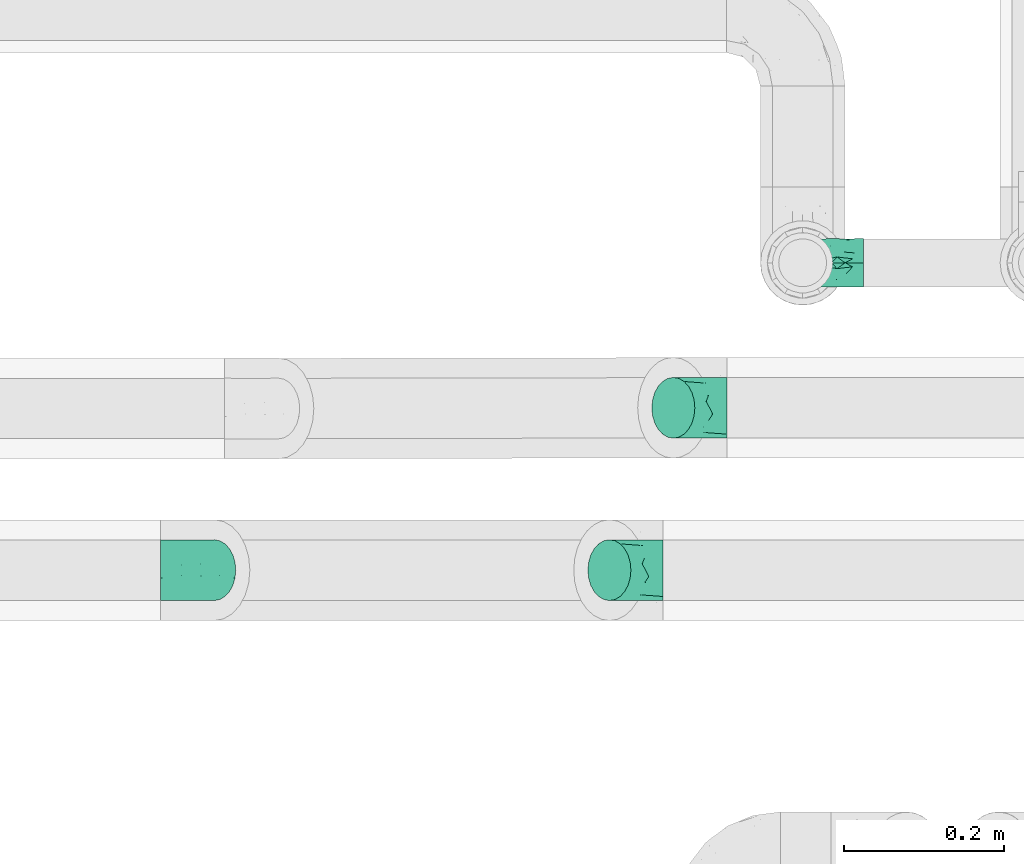
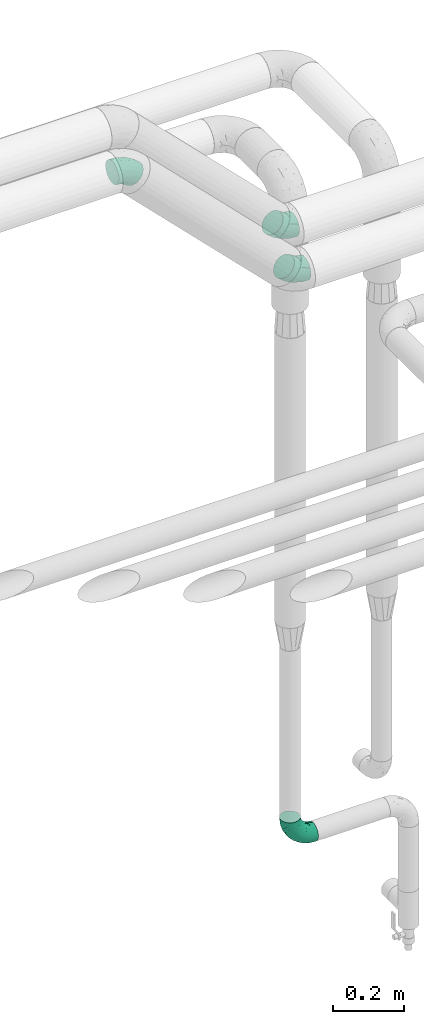
# One storey, part 681 of 827: 4 flow fittings.
"""IFC2X3 building model written with IfcOpenShell, lengths in millimetres."""

from ifc_helpers import new_model, entity, si_unit, converted_unit, derived_unit, direction, frame, origin, place, context, subcontext, project, spatial, faceted_brep, source, transform, mapped, material, type_object, type_shapes, element, save


model = new_model("IFC2X3")

# Units and contexts
model_context = context("Model", 3, precision=0.01, world=origin(), true_north=direction((6.12303176911189e-17, 1.0)))
body_context = subcontext(model_context, "Body", "Model", "MODEL_VIEW")
ifc_project = project(units=[si_unit("LENGTHUNIT", "METRE", prefix="MILLI"), si_unit("AREAUNIT", "SQUARE_METRE"), si_unit("VOLUMEUNIT", "CUBIC_METRE"), converted_unit("PLANEANGLEUNIT", "DEGREE", entity("IfcRatioMeasure", 0.0174532925199433), si_unit("PLANEANGLEUNIT", "RADIAN"), dimensions=[0, 0, 0, 0, 0, 0, 0]), si_unit("MASSUNIT", "GRAM", prefix="KILO"), derived_unit("MASSDENSITYUNIT", [(si_unit("MASSUNIT", "GRAM", prefix="KILO"), 1), (si_unit("LENGTHUNIT", "METRE"), -3)]), derived_unit("MOMENTOFINERTIAUNIT", [(si_unit("LENGTHUNIT", "METRE"), 4)]), si_unit("TIMEUNIT", "SECOND"), si_unit("FREQUENCYUNIT", "HERTZ"), si_unit("THERMODYNAMICTEMPERATUREUNIT", "DEGREE_CELSIUS"), derived_unit("THERMALTRANSMITTANCEUNIT", [(si_unit("MASSUNIT", "GRAM", prefix="KILO"), 1), (si_unit("THERMODYNAMICTEMPERATUREUNIT", "KELVIN"), -1), (si_unit("TIMEUNIT", "SECOND"), -3)]), derived_unit("VOLUMETRICFLOWRATEUNIT", [(si_unit("LENGTHUNIT", "METRE"), 3), (si_unit("TIMEUNIT", "SECOND"), -1)]), derived_unit("MASSFLOWRATEUNIT", [(si_unit("MASSUNIT", "GRAM", prefix="KILO"), 1), (si_unit("TIMEUNIT", "SECOND"), -1)]), derived_unit("ROTATIONALFREQUENCYUNIT", [(si_unit("TIMEUNIT", "SECOND"), -1)]), si_unit("ELECTRICCURRENTUNIT", "AMPERE"), si_unit("ELECTRICVOLTAGEUNIT", "VOLT"), si_unit("POWERUNIT", "WATT"), si_unit("FORCEUNIT", "NEWTON", prefix="KILO"), si_unit("ILLUMINANCEUNIT", "LUX"), si_unit("LUMINOUSFLUXUNIT", "LUMEN"), si_unit("LUMINOUSINTENSITYUNIT", "CANDELA"), derived_unit("USERDEFINED", [(si_unit("MASSUNIT", "GRAM", prefix="KILO"), -1), (si_unit("LENGTHUNIT", "METRE"), -2), (si_unit("TIMEUNIT", "SECOND"), 3), (si_unit("LUMINOUSFLUXUNIT", "LUMEN"), 1)]), derived_unit("LINEARVELOCITYUNIT", [(si_unit("LENGTHUNIT", "METRE"), 1), (si_unit("TIMEUNIT", "SECOND"), -1)]), si_unit("PRESSUREUNIT", "PASCAL"), derived_unit("USERDEFINED", [(si_unit("LENGTHUNIT", "METRE"), -2), (si_unit("MASSUNIT", "GRAM", prefix="KILO"), 1), (si_unit("TIMEUNIT", "SECOND"), -2)]), derived_unit("LINEARFORCEUNIT", [(si_unit("MASSUNIT", "GRAM", prefix="KILO"), 1), (si_unit("LENGTHUNIT", "METRE"), 1), (si_unit("TIMEUNIT", "SECOND"), -2), (si_unit("LENGTHUNIT", "METRE"), -1)]), derived_unit("PLANARFORCEUNIT", [(si_unit("MASSUNIT", "GRAM", prefix="KILO"), 1), (si_unit("LENGTHUNIT", "METRE"), 1), (si_unit("TIMEUNIT", "SECOND"), -2), (si_unit("LENGTHUNIT", "METRE"), -2)])], contexts=[model_context])

# Site, building, storey
site_placement = place(None, origin())
site = spatial("IfcSite", under=ifc_project, at=site_placement, CompositionType="ELEMENT")
building_placement = place(site_placement, origin())
building = spatial("IfcBuilding", under=site, at=building_placement, CompositionType="ELEMENT")
storey_placement = place(building_placement, frame((0.0, 0.0, 28200.0)))
storey = spatial("IfcBuildingStorey", under=building, at=storey_placement, Name="08", CompositionType="ELEMENT", Elevation=28200.0)

# Flow fittings
ifc_material = material()
pipe_fitting_type_1 = type_object("IfcPipeFittingType", Name="ADSK_1", PredefinedType="NOTDEFINED", material=ifc_material)
shared_shape_1 = source(origin(), body_context, "Body", "Brep", [
    faceted_brep([(-76.0, 15.07, -26.11), (-76.0, 7.8, -29.12), (-76.0, 0.0, -30.15), (-76.0, -7.8, -29.12), (-76.0, -15.08, -26.11), (-76.0, -21.32, -21.32), (-76.0, -26.11, -15.08), (-76.0, -29.12, -7.8), (-76.0, -30.15, 0.0), (-76.0, -29.12, 7.8), (-76.0, -26.11, 15.07), (-76.0, -21.32, 21.32), (-76.0, -15.08, 26.11), (-76.0, -7.8, 29.12), (-76.0, 0.0, 30.15), (-76.0, 7.8, 29.12), (-76.0, 15.07, 26.11), (-76.0, 21.32, 21.32), (-76.0, 26.11, 15.07), (-76.0, 29.12, 7.8), (-76.0, 30.15, 0.0), (-76.0, 29.12, -7.8), (-76.0, 26.11, -15.08), (-76.0, 21.32, -21.32), (0.0, 76.0, -30.15), (-7.8, 76.0, -29.12), (-15.07, 76.0, -26.11), (-21.32, 76.0, -21.32), (-26.11, 76.0, -15.08), (-29.12, 76.0, -7.8), (-30.15, 76.0, 0.0), (-29.12, 76.0, 7.8), (-26.11, 76.0, 15.07), (-21.32, 76.0, 21.32), (-15.07, 76.0, 26.11), (-7.8, 76.0, 29.12), (0.0, 76.0, 30.15), (7.8, 76.0, 29.12), (15.08, 76.0, 26.11), (21.32, 76.0, 21.32), (26.11, 76.0, 15.07), (29.12, 76.0, 7.8), (30.15, 76.0, 0.0), (29.12, 76.0, -7.8), (26.11, 76.0, -15.08), (21.32, 76.0, -21.32), (15.08, 76.0, -26.11), (7.8, 76.0, -29.12), (10.79, 31.43, 21.07), (4.32, 31.7, 25.72), (1.65, 15.19, 19.92), (-61.17, -27.8, 0.0), (-51.1, -25.49, 9.84), (-56.14, -10.61, 27.27), (-31.7, -4.32, 25.72), (-39.75, 1.72, 29.41), (-43.2, -24.95, 0.0), (-1.86, 1.86, 0.0), (4.49, 7.65, 5.78), (-7.82, -4.61, 5.83), (-56.21, -22.79, 17.21), (-58.98, -3.38, 29.7), (-53.96, 5.6, 30.07), (-10.86, 10.86, 25.48), (-17.2, -2.6, 20.44), (-49.15, -16.01, 22.7), (-22.18, -14.24, 7.99), (-28.4, -17.42, 0.0), (-13.61, -9.88, 0.0), (-39.0, 23.48, 27.76), (-58.76, 12.54, 28.36), (-41.61, 15.41, 29.48), (16.01, 49.15, 22.7), (-58.55, 25.93, 19.53), (-51.53, 33.5, 13.51), (-64.92, 28.76, 12.4), (-7.48, 23.14, 28.25), (-1.72, 39.75, 29.41), (-12.04, 27.88, 29.88), (-63.91, 18.81, 24.52), (-11.63, 65.16, 28.18), (-4.97, 57.02, 30.05), (9.88, 13.61, 0.0), (-62.5, 31.74, 5.02), (-45.17, 30.98, 21.2), (-21.78, 9.76, 28.58), (10.61, 56.14, 27.27), (-32.09, 54.42, 13.26), (22.79, 56.21, 17.21), (15.38, 31.17, 15.63), (25.49, 51.1, 9.84), (21.84, 36.35, 5.92), (24.95, 43.2, 0.0), (3.38, 58.98, 29.7), (-31.17, -15.38, 15.63), (-39.39, 41.78, 15.45), (-34.56, 41.13, 20.79), (-39.81, -23.25, 5.49), (27.8, 61.17, 0.0), (-31.74, 62.5, 5.02), (-53.07, 36.29, 0.0), (-42.95, 42.95, 7.29), (-36.29, 53.07, 0.0), (-19.83, 58.51, 24.79), (-25.48, 60.2, 19.41), (-14.53, 50.96, 28.57), (-13.31, 37.09, 30.07), (-26.16, 40.06, 26.4), (-32.43, -10.35, 21.9), (17.42, 28.4, 0.0), (14.24, 22.18, 7.99), (-38.67, 9.72, 30.15), (-24.66, 17.36, 30.09), (-37.08, 31.49, 24.99), (-49.27, 22.83, 25.24), (-20.8, 38.81, 28.63), (-27.58, 27.58, 29.2), (-36.07, -20.23, 10.71), (-15.19, -6.16, 14.9), (6.6, 15.4, 14.49), (-2.51, 2.51, 11.35), (-65.16, 11.63, -28.18), (-49.15, -16.01, -22.7), (-57.02, 4.97, -30.05), (-25.93, 58.55, -19.53), (-33.5, 51.53, -13.51), (-28.76, 64.92, -12.4), (-60.2, 25.48, -19.41), (-58.51, 19.83, -24.79), (4.61, 7.82, -5.83), (-7.65, -4.49, -5.78), (-2.51, 2.51, -11.35), (-62.5, 31.74, -5.02), (-50.96, 14.53, -28.57), (-37.09, 13.31, -30.07), (-42.95, 42.95, -7.29), (25.49, 51.1, -9.84), (22.79, 56.21, -17.21), (-40.06, 26.16, -26.4), (3.38, 58.98, -29.7), (-5.6, 53.96, -30.07), (-27.88, 12.04, -29.88), (-9.76, 21.78, -28.58), (-23.14, 7.48, -28.25), (-51.1, -25.49, -9.84), (15.38, 31.17, -15.63), (16.01, 49.15, -22.7), (-23.48, 39.0, -27.76), (-12.54, 58.76, -28.36), (-15.41, 41.61, -29.48), (-56.21, -22.79, -17.21), (-9.72, 38.67, -30.15), (-17.36, 24.66, -30.09), (-22.18, -14.24, -7.99), (-41.13, 34.56, -20.79), (-31.74, 62.5, -5.02), (-58.98, -3.38, -29.7), (-31.17, -15.38, -15.63), (-56.14, -10.61, -27.27), (14.24, 22.18, -7.99), (23.25, 39.81, -5.49), (-31.49, 37.08, -24.99), (-15.19, -6.16, -14.9), (1.65, 15.19, -19.92), (-18.81, 63.91, -24.52), (-32.59, -11.62, -20.84), (-31.7, -4.32, -25.72), (-17.2, -2.6, -20.44), (-39.75, 1.72, -29.41), (-54.42, 32.09, -13.26), (-30.98, 45.17, -21.2), (10.61, 56.14, -27.27), (10.23, 31.31, -21.52), (4.32, 31.7, -25.72), (-41.78, 39.39, -15.45), (-1.72, 39.75, -29.41), (-36.35, -21.84, -5.92), (-22.83, 49.27, -25.24), (-38.81, 20.8, -28.63), (-27.58, 27.58, -29.2), (-10.86, 10.86, -25.48), (20.23, 36.07, -10.71), (6.6, 15.4, -14.49)], [[[0, 1, 2, 3, 4, 5, 6, 7, 8, 9, 10, 11, 12, 13, 14, 15, 16, 17, 18, 19, 20, 21, 22, 23]], [[24, 25, 26, 27, 28, 29, 30, 31, 32, 33, 34, 35, 36, 37, 38, 39, 40, 41, 42, 43, 44, 45, 46, 47]], [[48, 49, 50]], [[51, 52, 9]], [[53, 54, 55]], [[9, 52, 10]], [[56, 52, 51]], [[57, 58, 59]], [[11, 10, 60]], [[14, 61, 62]], [[63, 54, 64]], [[65, 12, 11]], [[65, 53, 12]], [[66, 67, 68]], [[69, 70, 71]], [[72, 39, 38]], [[73, 74, 75]], [[15, 70, 16]], [[76, 77, 78]], [[16, 79, 17]], [[13, 61, 14]], [[35, 80, 81]], [[14, 62, 15]], [[17, 73, 18]], [[57, 82, 58]], [[20, 19, 83]], [[75, 19, 18]], [[70, 15, 62]], [[73, 84, 74]], [[78, 85, 76]], [[38, 86, 72]], [[32, 31, 87]], [[88, 89, 90]], [[91, 92, 90]], [[72, 86, 49]], [[36, 93, 37]], [[75, 83, 19]], [[36, 35, 81]], [[60, 94, 65]], [[40, 90, 41]], [[95, 96, 87]], [[88, 90, 40]], [[66, 97, 67]], [[90, 98, 41]], [[40, 39, 88]], [[99, 31, 30]], [[20, 83, 100]], [[101, 102, 100]], [[52, 60, 10]], [[102, 99, 30]], [[96, 103, 104]], [[83, 101, 100]], [[12, 53, 13]], [[104, 103, 33]], [[105, 106, 81]], [[107, 105, 103]], [[64, 54, 108]], [[80, 103, 105]], [[80, 35, 34]], [[34, 33, 103]], [[86, 38, 37]], [[109, 110, 82]], [[71, 111, 112]], [[69, 107, 113]], [[79, 73, 17]], [[114, 113, 84]], [[33, 32, 104]], [[115, 107, 116]], [[105, 115, 106]], [[93, 81, 77]], [[54, 53, 65]], [[61, 53, 55]], [[108, 94, 64]], [[54, 63, 85]], [[93, 86, 37]], [[77, 76, 49]], [[77, 49, 86]], [[49, 63, 50]], [[60, 52, 117]], [[65, 11, 60]], [[39, 72, 88]], [[89, 88, 72]], [[71, 70, 62]], [[79, 70, 114]], [[103, 96, 107]], [[69, 113, 114]], [[112, 106, 116]], [[77, 81, 106]], [[112, 116, 71]], [[112, 55, 85]], [[64, 50, 63]], [[57, 59, 68]], [[32, 87, 104]], [[96, 104, 87]], [[94, 118, 64]], [[50, 119, 89]], [[50, 64, 118]], [[50, 89, 48]], [[81, 93, 36]], [[86, 93, 77]], [[53, 61, 13]], [[62, 61, 55]], [[71, 62, 111]], [[69, 71, 116]], [[95, 101, 74]], [[99, 101, 87]], [[118, 66, 59]], [[117, 97, 66]], [[117, 66, 94]], [[91, 89, 110]], [[91, 110, 109]], [[110, 89, 119]], [[9, 8, 51]], [[98, 90, 92]], [[98, 42, 41]], [[101, 83, 74]], [[101, 99, 102]], [[87, 31, 99]], [[62, 55, 111]], [[55, 112, 111]], [[107, 69, 116]], [[70, 69, 114]], [[107, 96, 113]], [[84, 113, 96]], [[84, 96, 95]], [[114, 84, 73]], [[70, 79, 16]], [[73, 79, 114]], [[54, 85, 55]], [[76, 85, 63]], [[49, 76, 63]], [[77, 106, 78]], [[106, 112, 78]], [[85, 78, 112]], [[73, 75, 18]], [[83, 75, 74]], [[103, 80, 34]], [[81, 80, 105]], [[101, 95, 87]], [[84, 95, 74]], [[106, 115, 116]], [[105, 107, 115]], [[120, 59, 58]], [[82, 110, 58]], [[119, 58, 110]], [[118, 59, 120]], [[66, 68, 59]], [[54, 65, 108]], [[94, 108, 65]], [[66, 118, 94]], [[50, 118, 120]], [[50, 120, 119]], [[119, 120, 58]], [[89, 72, 48]], [[49, 48, 72]], [[60, 117, 94]], [[117, 52, 97]], [[52, 56, 97]], [[67, 97, 56]], [[92, 91, 109]], [[89, 91, 90]], [[121, 1, 0]], [[122, 5, 4]], [[2, 1, 123]], [[124, 125, 126]], [[127, 128, 23]], [[129, 130, 131]], [[100, 132, 20]], [[133, 134, 123]], [[135, 100, 102]], [[136, 137, 44]], [[133, 128, 138]], [[24, 139, 140]], [[141, 142, 143]], [[121, 128, 133]], [[6, 144, 7]], [[137, 145, 146]], [[144, 51, 7]], [[147, 148, 149]], [[144, 6, 150]], [[149, 151, 152]], [[153, 68, 67]], [[154, 128, 127]], [[30, 155, 102]], [[43, 42, 98]], [[156, 3, 2]], [[157, 144, 150]], [[158, 4, 3]], [[24, 140, 25]], [[155, 135, 102]], [[159, 160, 109]], [[30, 29, 155]], [[147, 138, 161]], [[27, 124, 28]], [[57, 129, 82]], [[162, 163, 131]], [[27, 26, 164]], [[148, 26, 25]], [[165, 166, 167]], [[24, 47, 139]], [[143, 168, 141]], [[22, 21, 169]], [[125, 124, 170]], [[148, 25, 140]], [[46, 146, 171]], [[158, 122, 4]], [[0, 23, 128]], [[1, 121, 123]], [[109, 82, 159]], [[45, 44, 137]], [[146, 46, 45]], [[136, 43, 98]], [[132, 21, 20]], [[136, 98, 92]], [[172, 173, 146]], [[46, 171, 47]], [[43, 136, 44]], [[174, 154, 169]], [[171, 173, 175]], [[6, 5, 150]], [[126, 29, 28]], [[176, 56, 144]], [[122, 158, 166]], [[164, 124, 27]], [[177, 161, 170]], [[23, 22, 127]], [[178, 138, 179]], [[133, 178, 134]], [[156, 123, 168]], [[156, 158, 3]], [[168, 143, 166]], [[168, 166, 158]], [[166, 180, 167]], [[173, 171, 146]], [[139, 171, 175]], [[172, 145, 163]], [[173, 180, 142]], [[5, 122, 150]], [[157, 150, 122]], [[137, 136, 181]], [[146, 45, 137]], [[149, 148, 140]], [[164, 148, 177]], [[128, 154, 138]], [[147, 161, 177]], [[152, 134, 179]], [[168, 123, 134]], [[152, 179, 149]], [[152, 175, 142]], [[57, 130, 129]], [[157, 165, 167]], [[22, 169, 127]], [[154, 127, 169]], [[163, 167, 180]], [[162, 157, 167]], [[173, 163, 180]], [[182, 163, 145]], [[123, 156, 2]], [[158, 156, 168]], [[171, 139, 47]], [[140, 139, 175]], [[149, 140, 151]], [[147, 149, 179]], [[174, 135, 125]], [[132, 135, 169]], [[176, 157, 153]], [[176, 153, 67]], [[153, 157, 162]], [[182, 159, 129]], [[181, 160, 159]], [[181, 159, 145]], [[51, 144, 56]], [[51, 8, 7]], [[135, 132, 100]], [[169, 21, 132]], [[126, 155, 29]], [[135, 155, 125]], [[140, 175, 151]], [[175, 152, 151]], [[138, 147, 179]], [[148, 147, 177]], [[138, 154, 161]], [[170, 161, 154]], [[170, 154, 174]], [[177, 170, 124]], [[148, 164, 26]], [[124, 164, 177]], [[173, 142, 175]], [[143, 142, 180]], [[166, 143, 180]], [[168, 134, 141]], [[134, 152, 141]], [[142, 141, 152]], [[124, 126, 28]], [[155, 126, 125]], [[128, 121, 0]], [[123, 121, 133]], [[135, 174, 169]], [[170, 174, 125]], [[134, 178, 179]], [[133, 138, 178]], [[130, 153, 162]], [[68, 153, 130]], [[57, 68, 130]], [[182, 129, 131]], [[159, 82, 129]], [[157, 122, 165]], [[166, 165, 122]], [[163, 162, 167]], [[162, 131, 130]], [[145, 172, 146]], [[163, 173, 172]], [[159, 182, 145]], [[131, 163, 182]], [[56, 176, 67]], [[157, 176, 144]], [[137, 181, 145]], [[181, 136, 160]], [[136, 92, 160]], [[109, 160, 92]]]),
])
type_shapes(pipe_fitting_type_1, [shared_shape_1])
flow_fitting_placement = place(storey_placement, frame((46507.82, 18991.22, 730.0), z_axis=(0.0, -1.0, 0.0), x_axis=(0.0, 0.0, -1.0)))
element("IfcFlowFitting", 1, at=flow_fitting_placement, inside=storey, type_object=pipe_fitting_type_1, material=ifc_material, Name="ADSK_1", ObjectType="ADSK_1", context=body_context, shape_type="MappedRepresentation", body=[
    mapped(shared_shape_1, transform((0.0, 0.0, 0.0), scale=1.0)),
])
pipe_fitting_type_2 = type_object("IfcPipeFittingType", Name="ADSK_1", PredefinedType="NOTDEFINED", material=ifc_material)
shared_shape_2 = source(origin(), body_context, "Body", "Brep", [
    faceted_brep([(-39.35, 19.02, -32.95), (-39.35, 9.85, -36.75), (-39.35, 0.0, -38.05), (-39.35, -9.85, -36.75), (-39.35, -19.03, -32.95), (-39.35, -26.91, -26.91), (-39.35, -32.95, -19.03), (-39.35, -36.75, -9.85), (-39.35, -38.05, 0.0), (-39.35, -36.75, 9.85), (-39.35, -32.95, 19.02), (-39.35, -26.91, 26.91), (-39.35, -19.03, 32.95), (-39.35, -9.85, 36.75), (-39.35, 0.0, 38.05), (-39.35, 9.85, 36.75), (-39.35, 19.02, 32.95), (-39.35, 26.91, 26.91), (-39.35, 32.95, 19.02), (-39.35, 36.75, 9.85), (-39.35, 38.05, 0.0), (-39.35, 36.75, -9.85), (-39.35, 32.95, -19.03), (-39.35, 26.91, -26.91), (27.82, 27.82, -38.05), (20.86, 34.79, -36.75), (14.37, 41.28, -32.95), (8.8, 46.85, -26.91), (4.52, 51.13, -19.03), (1.84, 53.81, -9.85), (0.92, 54.73, 0.0), (1.84, 53.81, 9.85), (4.52, 51.13, 19.02), (8.8, 46.85, 26.91), (14.37, 41.28, 32.95), (20.86, 34.79, 36.75), (27.82, 27.82, 38.05), (34.79, 20.86, 36.75), (41.28, 14.37, 32.95), (46.85, 8.8, 26.91), (51.13, 4.52, 19.02), (53.81, 1.84, 9.85), (54.73, 0.92, 0.0), (53.81, 1.84, -9.85), (51.13, 4.52, -19.03), (46.85, 8.8, -26.91), (41.28, 14.37, -32.95), (34.79, 20.86, -36.75), (-16.48, -28.6, 22.48), (-9.83, -32.19, 13.52), (8.97, -21.66, 21.67), (-20.54, -35.57, 0.0), (-4.91, -33.52, 0.0), (-13.54, -34.93, 6.65), (-11.41, -20.66, 29.54), (31.88, -8.57, 22.48), (-19.69, -13.48, 34.86), (3.15, -7.61, 34.49), (12.7, 20.76, 37.8), (-14.37, -2.8, 37.58), (-4.35, 10.49, 37.89), (-23.66, 5.7, 37.8), (22.68, -6.54, 29.54), (23.46, 4.39, 34.86), (-17.67, 16.65, 35.5), (-11.48, 27.71, 30.93), (-5.05, 36.47, 26.65), (11.57, -24.66, 14.82), (11.29, -27.26, 7.35), (-19.91, 32.6, 23.86), (-16.29, 39.33, 15.52), (34.27, -15.12, 6.65), (39.68, -10.63, 0.0), (-13.09, 43.52, 7.94), (12.14, 8.18, 37.58), (29.72, -15.81, 13.52), (2.92, 25.68, 35.46), (5.55, -13.39, 30.82), (-17.56, 42.39, 0.0), (-7.75, 40.18, 21.01), (11.13, -26.87, 0.0), (27.17, -20.22, 0.0), (-14.37, -2.8, -37.58), (-13.54, -34.93, -6.65), (11.26, -27.2, -7.7), (0.72, 24.27, -35.5), (-23.66, 5.7, -37.8), (-21.52, 40.03, -7.94), (-16.29, 39.33, -15.52), (22.68, -6.54, -29.54), (-22.21, 29.36, -26.65), (29.72, -15.81, -13.52), (-22.93, 33.89, -21.01), (-8.97, 37.13, -23.86), (12.14, 8.18, -37.58), (-20.22, 16.09, -35.46), (-9.83, -32.19, -13.52), (31.88, -8.57, -22.48), (-16.48, -28.6, -22.48), (8.97, -21.66, -21.67), (8.74, -25.75, -14.99), (-11.41, -20.66, -29.54), (5.55, -13.39, -30.82), (3.15, -7.61, -34.49), (-19.69, -13.48, -34.86), (-11.48, 27.71, -30.93), (34.27, -15.12, -6.65), (12.7, 20.76, -37.8), (23.46, 4.39, -34.86), (-4.35, 10.49, -37.89)], [[[0, 1, 2, 3, 4, 5, 6, 7, 8, 9, 10, 11, 12, 13, 14, 15, 16, 17, 18, 19, 20, 21, 22, 23]], [[24, 25, 26, 27, 28, 29, 30, 31, 32, 33, 34, 35, 36, 37, 38, 39, 40, 41, 42, 43, 44, 45, 46, 47]], [[48, 49, 50]], [[51, 52, 53]], [[12, 11, 54]], [[40, 39, 55]], [[56, 54, 57]], [[48, 11, 10]], [[36, 35, 58]], [[13, 12, 56]], [[59, 60, 61]], [[14, 13, 59]], [[62, 55, 39]], [[38, 37, 63]], [[61, 15, 14]], [[16, 64, 65]], [[9, 51, 53]], [[33, 66, 34]], [[67, 49, 68]], [[65, 17, 16]], [[18, 17, 69]], [[18, 69, 70]], [[19, 18, 70]], [[41, 71, 72]], [[73, 20, 19]], [[52, 68, 53]], [[49, 53, 68]], [[16, 15, 64]], [[36, 58, 74]], [[39, 38, 62]], [[57, 74, 59]], [[74, 37, 36]], [[66, 69, 65]], [[75, 40, 55]], [[60, 58, 76]], [[62, 38, 63]], [[17, 65, 69]], [[71, 41, 75]], [[49, 48, 10]], [[61, 64, 15]], [[77, 50, 62]], [[19, 70, 73]], [[10, 9, 49]], [[78, 73, 30]], [[48, 54, 11]], [[31, 73, 70]], [[57, 63, 74]], [[69, 66, 79]], [[55, 62, 50]], [[79, 70, 69]], [[56, 59, 13]], [[35, 34, 76]], [[76, 65, 64]], [[54, 77, 57]], [[60, 59, 74]], [[75, 41, 40]], [[54, 48, 50]], [[32, 31, 70]], [[75, 55, 50]], [[65, 76, 34]], [[60, 76, 64]], [[54, 56, 12]], [[59, 56, 57]], [[74, 63, 37]], [[62, 63, 57]], [[9, 8, 51]], [[68, 52, 80, 81]], [[9, 53, 49]], [[71, 68, 81]], [[68, 75, 67]], [[72, 71, 81]], [[72, 42, 41]], [[68, 71, 75]], [[59, 61, 14]], [[64, 61, 60]], [[76, 58, 35]], [[74, 58, 60]], [[30, 73, 31]], [[73, 78, 20]], [[50, 77, 54]], [[62, 57, 77]], [[34, 66, 65]], [[79, 33, 32]], [[33, 79, 66]], [[32, 70, 79]], [[75, 50, 67]], [[49, 67, 50]], [[3, 2, 82]], [[52, 83, 84]], [[26, 25, 85]], [[2, 1, 86]], [[21, 87, 88]], [[46, 45, 89]], [[0, 23, 90]], [[44, 43, 91]], [[92, 88, 93]], [[24, 47, 94]], [[29, 28, 88]], [[1, 0, 95]], [[83, 7, 96]], [[91, 97, 44]], [[98, 99, 100]], [[98, 96, 6]], [[5, 4, 101]], [[89, 102, 103]], [[7, 6, 96]], [[5, 98, 6]], [[104, 4, 3]], [[90, 93, 105]], [[101, 98, 5]], [[28, 27, 93]], [[20, 78, 87]], [[27, 105, 93]], [[30, 29, 87]], [[102, 99, 101]], [[105, 85, 95]], [[88, 22, 21]], [[28, 93, 88]], [[104, 101, 4]], [[85, 105, 26]], [[90, 92, 93]], [[86, 82, 2]], [[27, 26, 105]], [[43, 72, 106]], [[107, 25, 24]], [[108, 47, 46]], [[7, 83, 51]], [[44, 97, 45]], [[103, 108, 89]], [[97, 89, 45]], [[109, 107, 94]], [[99, 97, 91]], [[109, 94, 82]], [[106, 72, 81]], [[108, 94, 47]], [[103, 104, 82]], [[83, 96, 84]], [[103, 82, 94]], [[100, 91, 84]], [[107, 85, 25]], [[29, 88, 87]], [[109, 86, 95]], [[98, 101, 99]], [[89, 97, 99]], [[105, 95, 0]], [[109, 95, 85]], [[82, 104, 3]], [[101, 104, 103]], [[89, 108, 46]], [[94, 108, 103]], [[51, 83, 52]], [[51, 8, 7]], [[100, 84, 96]], [[106, 84, 91]], [[84, 81, 80, 52]], [[43, 42, 72]], [[84, 106, 81]], [[43, 106, 91]], [[95, 86, 1]], [[82, 86, 109]], [[94, 107, 24]], [[85, 107, 109]], [[20, 87, 21]], [[87, 78, 30]], [[99, 102, 89]], [[101, 103, 102]], [[0, 90, 105]], [[92, 23, 22]], [[23, 92, 90]], [[22, 88, 92]], [[98, 100, 96]], [[91, 100, 99]]]),
])
type_shapes(pipe_fitting_type_2, [shared_shape_2])
for number, where, z_axis, x_axis, name in (
    (2, (46293.82, 18606.7, 3000.0), (0.0, 1.0, 0.0), (-1.0, 0.0, 0.0), "ADSK_1"),
    (3, (45743.82, 18606.7, 3550.0), (0.0, -1.0, 0.0), (-0.707106781186536, 0.0, 0.707106781186559), "ADSK_1"),
    (4, (46373.82, 18809.82, 3000.0), (0.0, 1.0, 0.0), (-1.0, 0.0, 0.0), "ADSK_1"),
):
    element("IfcFlowFitting", number, at=place(storey_placement, frame(where, z_axis=z_axis, x_axis=x_axis)), inside=storey, type_object=pipe_fitting_type_2, material=ifc_material, Name=name, ObjectType="ADSK_1", context=body_context, shape_type="MappedRepresentation", body=[
        mapped(shared_shape_2, transform((0.0, 0.0, 0.0), scale=1.0)),
    ])

save(model, "model.ifc")
